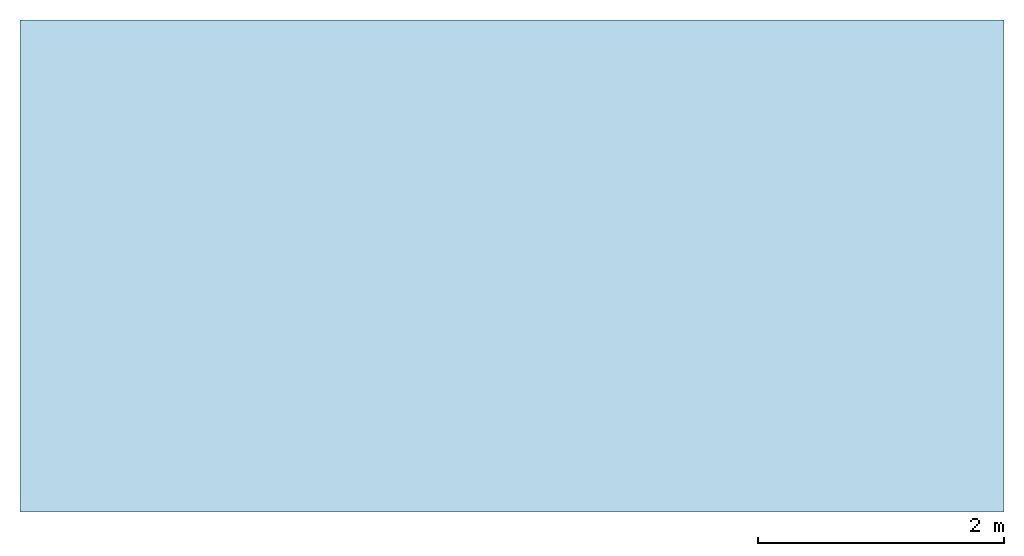
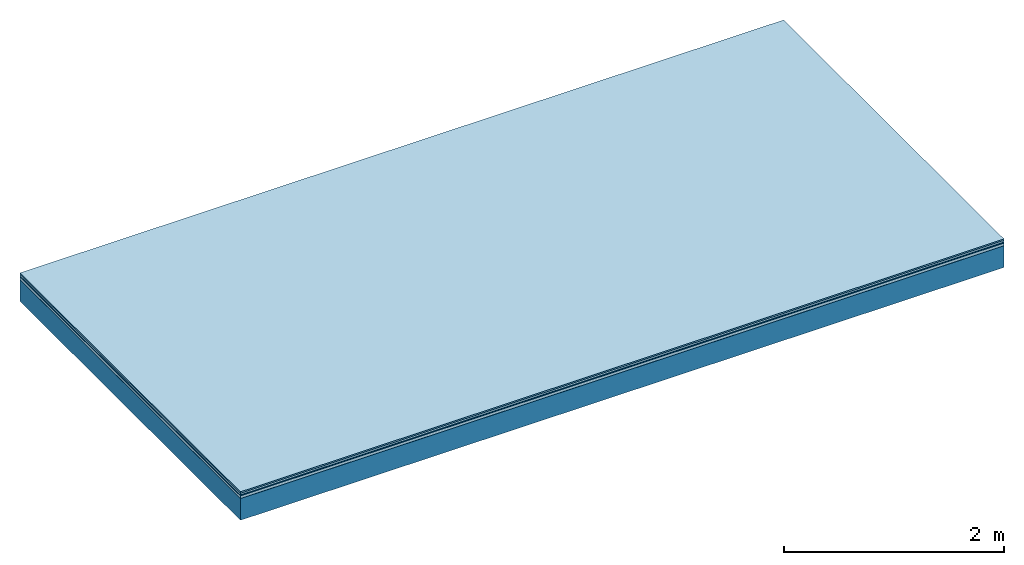
# One storey: 5 plates, 1 member, 1 element without a shape of its own.
"""IFC4 building model written with IfcOpenShell, lengths in metres."""

from ifc_helpers import new_model, si_unit, derived_unit, direction, frame, frame_2d, origin, origin_with_axes, place, context, project, spatial, rectangle, extrude, material, layer, layer_set, type_object, element, aggregate, save


model = new_model("IFC4")

# Units and contexts
plan_context = context("Plan", 3, precision=1e-05, world=origin(), true_north=direction((0.0, 1.0)))
model_context = context("Model", 3, precision=1e-05, world=origin(), true_north=direction((0.0, 1.0)))
ifc_project = project(units=[si_unit("LENGTHUNIT", "METRE"), derived_unit("SOUNDPRESSUREUNIT", [(si_unit("PRESSUREUNIT", "PASCAL", prefix="MICRO"), 0)]), si_unit("ENERGYUNIT", "JOULE", prefix="MEGA"), si_unit("MASSUNIT", "GRAM", prefix="KILO"), derived_unit("THERMALTRANSMITTANCEUNIT", [(si_unit("POWERUNIT", "WATT"), 1), (si_unit("AREAUNIT", "SQUARE_METRE"), -1), (si_unit("THERMODYNAMICTEMPERATUREUNIT", "KELVIN"), -1)]), derived_unit("AREADENSITYUNIT", [(si_unit("MASSUNIT", "GRAM", prefix="KILO"), 1), (si_unit("AREAUNIT", "SQUARE_METRE"), -1)]), derived_unit("USERDEFINED", [(si_unit("ENERGYUNIT", "JOULE", prefix="MEGA"), 1), (si_unit("AREAUNIT", "SQUARE_METRE"), -1)])], contexts=[plan_context, model_context])

# Site, building, storey
site = spatial("IfcSite", under=ifc_project)
building_placement = place(None, origin())
building = spatial("IfcBuilding", under=site, at=building_placement)
storey_placement = place(building_placement, origin())
storey = spatial("IfcBuildingStorey", under=building, at=storey_placement)

# Slab, member, plates
ifc_material_1 = material(Category="11.013")
ifc_layer_1 = layer(ifc_material_1, 0.015, Name="Flooring")
ifc_material_2 = material(Category="03.007")
ifc_layer_2 = layer(ifc_material_2, 0.02, Name="On-material")
ifc_material_3 = material(Name="Wood fiber generic product", Category="10.009")
ifc_layer_3 = layer(ifc_material_3, 0.01, Name="Impact sound insulation")
ifc_material_4 = material(Name="with broken")
ifc_layer_4 = layer(ifc_material_4, 0.03, Name="on Supporting structure")
ifc_material_5 = material(Name="protection", Category="09.007")
ifc_layer_5 = layer(ifc_material_5, 0.0005, Name="Sub-floor")
ifc_material_6 = material(Name="no composite action")
ifc_layer_6 = layer(ifc_material_6, 0.0, Name="Bond")
ifc_layer_7 = layer(None, 0.24, Name="Supporting structure")
ifc_layer_set = layer_set([ifc_layer_1, ifc_layer_2, ifc_layer_3, ifc_layer_4, ifc_layer_5, ifc_layer_6, ifc_layer_7])
slab_type = type_object("IfcSlabType", Name="A2048", PredefinedType="NOTDEFINED", material=ifc_layer_set)
slab_placement = place(None, frame((0.0, 0.0, 0.0), z_axis=(0.0, 0.0, -1.0), x_axis=(1.0, 0.0, 0.0)))
slab = element("IfcSlab", 1, at=slab_placement, inside=storey, type_object=slab_type, material=ifc_layer_set, Name="Slab #1")
ifc_material_7 = material(Name="Solid timber panel")
member_placement = place(slab_placement, origin())
member = element("IfcMember", 2, at=member_placement, material=ifc_material_7, Name="Supporting structure", context=plan_context, shape_type="SweptSolid", body=[
    extrude(rectangle(XDim=1.0, YDim=0.24, at=frame_2d((0.5, 0.12), x_axis=(1.0, 0.0))), frame((0.0, 4.0, 0.0755), z_axis=(0.0, -1.0, 0.0), x_axis=(1.0, 0.0, 0.0)), (0.0, 0.0, 1.0), 4.0),
    extrude(rectangle(XDim=1.0, YDim=0.24, at=frame_2d((0.5, 0.12), x_axis=(1.0, 0.0))), frame((1.0, 4.0, 0.0755), z_axis=(0.0, -1.0, 0.0), x_axis=(1.0, 0.0, 0.0)), (0.0, 0.0, 1.0), 4.0),
    extrude(rectangle(XDim=1.0, YDim=0.24, at=frame_2d((0.5, 0.12), x_axis=(1.0, 0.0))), frame((2.0, 4.0, 0.0755), z_axis=(0.0, -1.0, 0.0), x_axis=(1.0, 0.0, 0.0)), (0.0, 0.0, 1.0), 4.0),
    extrude(rectangle(XDim=1.0, YDim=0.24, at=frame_2d((0.5, 0.12), x_axis=(1.0, 0.0))), frame((3.0, 4.0, 0.0755), z_axis=(0.0, -1.0, 0.0), x_axis=(1.0, 0.0, 0.0)), (0.0, 0.0, 1.0), 4.0),
    extrude(rectangle(XDim=1.0, YDim=0.24, at=frame_2d((0.5, 0.12), x_axis=(1.0, 0.0))), frame((4.0, 4.0, 0.0755), z_axis=(0.0, -1.0, 0.0), x_axis=(1.0, 0.0, 0.0)), (0.0, 0.0, 1.0), 4.0),
    extrude(rectangle(XDim=1.0, YDim=0.24, at=frame_2d((0.5, 0.12), x_axis=(1.0, 0.0))), frame((5.0, 4.0, 0.0755), z_axis=(0.0, -1.0, 0.0), x_axis=(1.0, 0.0, 0.0)), (0.0, 0.0, 1.0), 4.0),
    extrude(rectangle(XDim=1.0, YDim=0.24, at=frame_2d((0.5, 0.12), x_axis=(1.0, 0.0))), frame((6.0, 4.0, 0.0755), z_axis=(0.0, -1.0, 0.0), x_axis=(1.0, 0.0, 0.0)), (0.0, 0.0, 1.0), 4.0),
    extrude(rectangle(XDim=1.0, YDim=0.24, at=frame_2d((0.5, 0.12), x_axis=(1.0, 0.0))), frame((7.0, 4.0, 0.0755), z_axis=(0.0, -1.0, 0.0), x_axis=(1.0, 0.0, 0.0)), (0.0, 0.0, 1.0), 4.0),
])
plate_1_placement = place(slab_placement, origin())
plate_1 = element("IfcPlate", 3, at=plate_1_placement, material=ifc_material_1, Name="Flooring", context=plan_context, shape_type="SweptSolid", body=[
    extrude(rectangle(XDim=8.0, YDim=4.0, at=frame_2d((4.0, 2.0), x_axis=(1.0, 0.0))), origin_with_axes(), (0.0, 0.0, 1.0), 0.015),
])
plate_2_placement = place(slab_placement, origin())
plate_2 = element("IfcPlate", 4, at=plate_2_placement, material=ifc_material_2, Name="On-material", context=plan_context, shape_type="SweptSolid", body=[
    extrude(rectangle(XDim=8.0, YDim=4.0, at=frame_2d((4.0, 2.0), x_axis=(1.0, 0.0))), frame((0.0, 0.0, 0.015), z_axis=(0.0, 0.0, 1.0), x_axis=(1.0, 0.0, 0.0)), (0.0, 0.0, 1.0), 0.02),
])
plate_3_placement = place(slab_placement, origin())
plate_3 = element("IfcPlate", 5, at=plate_3_placement, material=ifc_material_3, Name="Impact sound insulation", context=plan_context, shape_type="SweptSolid", body=[
    extrude(rectangle(XDim=8.0, YDim=4.0, at=frame_2d((4.0, 2.0), x_axis=(1.0, 0.0))), frame((0.0, 0.0, 0.035), z_axis=(0.0, 0.0, 1.0), x_axis=(1.0, 0.0, 0.0)), (0.0, 0.0, 1.0), 0.01),
])
plate_4_placement = place(slab_placement, origin())
plate_4 = element("IfcPlate", 6, at=plate_4_placement, material=ifc_material_4, Name="on Supporting structure", context=plan_context, shape_type="SweptSolid", body=[
    extrude(rectangle(XDim=8.0, YDim=4.0, at=frame_2d((4.0, 2.0), x_axis=(1.0, 0.0))), frame((0.0, 0.0, 0.045), z_axis=(0.0, 0.0, 1.0), x_axis=(1.0, 0.0, 0.0)), (0.0, 0.0, 1.0), 0.03),
])
plate_5_placement = place(slab_placement, origin())
plate_5 = element("IfcPlate", 7, at=plate_5_placement, material=ifc_material_5, Name="Sub-floor", context=plan_context, shape_type="SweptSolid", body=[
    extrude(rectangle(XDim=8.0, YDim=4.0, at=frame_2d((4.0, 2.0), x_axis=(1.0, 0.0))), frame((0.0, 0.0, 0.075), z_axis=(0.0, 0.0, 1.0), x_axis=(1.0, 0.0, 0.0)), (0.0, 0.0, 1.0), 0.0005),
])
aggregate(slab, [plate_1, plate_2, plate_3, plate_4, plate_5, member])

save(model, "model.ifc")
